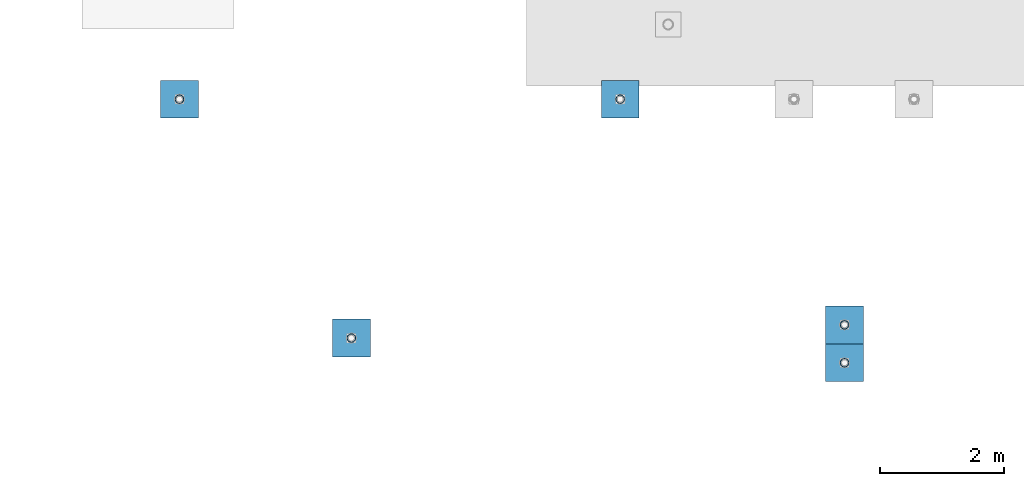
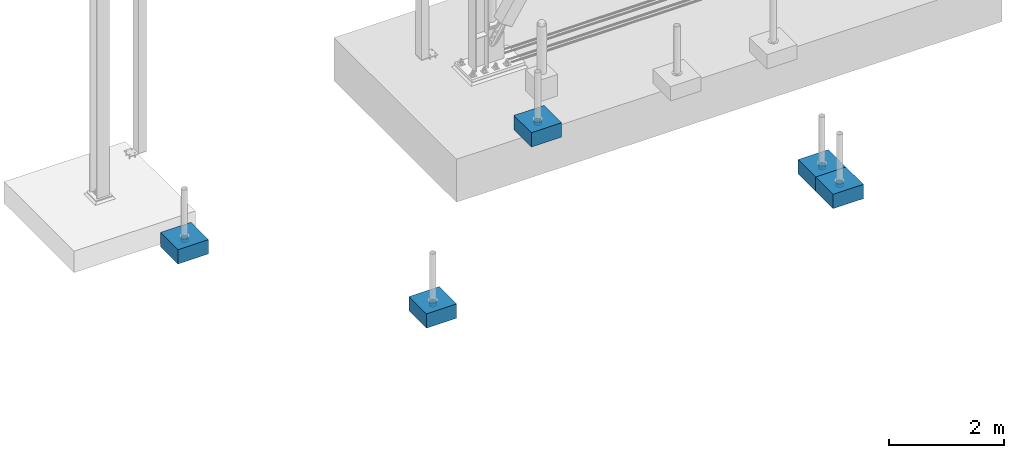
# One storey, part 1559 of 3843: 10 columns, 10 elements without a shape of their own.
"""IFC2X3 building model written with IfcOpenShell, lengths in millimetres."""

from ifc_helpers import new_model, si_unit, frame, origin_with_axes, place, context, subcontext, project, spatial, faceted_brep, material, type_object, element, aggregate, save


model = new_model("IFC2X3")

# Units and contexts
model_context = context("Model", 3, precision=1e-05, world=origin_with_axes())
body_context = subcontext(model_context, "Body", "Model", "MODEL_VIEW")
ifc_project = project(units=[si_unit("LENGTHUNIT", "METRE", prefix="MILLI"), si_unit("AREAUNIT", "SQUARE_METRE"), si_unit("VOLUMEUNIT", "CUBIC_METRE"), si_unit("MASSUNIT", "GRAM", prefix="KILO"), si_unit("TIMEUNIT", "SECOND"), si_unit("PLANEANGLEUNIT", "RADIAN"), si_unit("SOLIDANGLEUNIT", "STERADIAN"), si_unit("THERMODYNAMICTEMPERATUREUNIT", "DEGREE_CELSIUS"), si_unit("LUMINOUSINTENSITYUNIT", "LUMEN")], contexts=[model_context])

# Site, building, storey
site_placement = place(None, origin_with_axes())
site = spatial("IfcSite", under=ifc_project, at=site_placement, CompositionType="ELEMENT")
building_placement = place(site_placement, origin_with_axes())
building = spatial("IfcBuilding", under=site, at=building_placement, Name="Undefined", CompositionType="ELEMENT")
storey_placement = place(building_placement, origin_with_axes())
storey = spatial("IfcBuildingStorey", under=building, at=storey_placement, Name="Undefined", CompositionType="ELEMENT", Elevation=0.0)

# Assembly, column
assembly_1_placement = place(storey_placement, origin_with_axes())
assembly_1 = element("IfcElementAssembly", 1, at=assembly_1_placement, inside=storey, Name="PLATE", AssemblyPlace="NOTDEFINED", PredefinedType="RIGID_FRAME")
ifc_material_1 = material()
column_type_1 = type_object("IfcColumnType", Name="PIPE5SCH40", PredefinedType="NOTDEFINED")
column_1_placement = place(assembly_1_placement, frame((26313.3354032338, 82517.5288393497, 30378.4), z_axis=(-1.0, 0.0, 0.0), x_axis=(0.0, 0.0, 1.0)))
column_1 = element("IfcColumn", 2, at=column_1_placement, type_object=column_type_1, material=ifc_material_1, Name="PIPE_SLEEVE", ObjectType="PIPE5SCH40", context=body_context, shape_type="Brep", body=[
    faceted_brep([(0.0, -64.0587999999998, 0.0), (0.0, -60.9235391660477, 19.7952578392724), (76.2000000000007, -60.9235391660477, 19.7952578392724), (76.2000000000007, -64.0587999999998, 0.0), (0.0, -51.8246578392655, 37.6528179195593), (76.2000000000007, -51.8246578392655, 37.6528179195593), (0.0, -37.6528179195529, 51.8246578392718), (76.2000000000007, -37.6528179195529, 51.8246578392718), (0.0, -19.795257839266, 60.9235391660477), (76.2000000000007, -19.795257839266, 60.9235391660477), (0.0, 0.0, 64.0587999999989), (76.2000000000007, 0.0, 64.0587999999989), (0.0, 19.795257839266, 60.9235391660477), (76.2000000000007, 19.795257839266, 60.9235391660477), (0.0, 37.6528179195529, 51.8246578392718), (76.2000000000007, 37.6528179195529, 51.8246578392718), (0.0, 51.8246578392655, 37.6528179195593), (76.2000000000007, 51.8246578392655, 37.6528179195593), (0.0, 60.9235391660477, 19.7952578392724), (76.2000000000007, 60.9235391660477, 19.7952578392724), (0.0, 64.0587999999998, 0.0), (76.2000000000007, 64.0587999999998, 0.0), (0.0, 60.9235391660477, -19.7952578392724), (76.2000000000007, 60.9235391660477, -19.7952578392724), (0.0, 51.8246578392655, -37.6528179195593), (76.2000000000007, 51.8246578392655, -37.6528179195593), (0.0, 37.6528179195529, -51.8246578392718), (76.2000000000007, 37.6528179195529, -51.8246578392718), (0.0, 19.795257839266, -60.9235391660477), (76.2000000000007, 19.795257839266, -60.9235391660477), (0.0, 0.0, -64.0587999999989), (76.2000000000007, 0.0, -64.0587999999989), (0.0, -19.795257839266, -60.9235391660477), (76.2000000000007, -19.795257839266, -60.9235391660477), (0.0, -37.6528179195529, -51.8246578392718), (76.2000000000007, -37.6528179195529, -51.8246578392718), (0.0, -51.8246578392655, -37.6528179195593), (76.2000000000007, -51.8246578392655, -37.6528179195593), (0.0, -60.9235391660477, -19.7952578392724), (76.2000000000007, -60.9235391660477, -19.7952578392724), (0.0, -70.6120000000001, 0.0), (0.0, -67.1560027286332, -21.8203080068051), (76.2000000000007, -67.1560027286332, -21.8203080068051), (76.2000000000007, -70.6120000000001, 0.0), (0.0, -57.1263080068038, -41.5046922348702), (76.2000000000007, -57.1263080068038, -41.5046922348702), (0.0, -41.5046922348765, -57.126308006802), (76.2000000000007, -41.5046922348765, -57.126308006802), (0.0, -21.8203080068042, -67.1560027286323), (76.2000000000007, -21.8203080068042, -67.1560027286323), (0.0, 0.0, -70.6119999999937), (76.2000000000007, 0.0, -70.6119999999937), (0.0, 21.8203080068042, -67.1560027286323), (76.2000000000007, 21.8203080068042, -67.1560027286323), (0.0, 41.5046922348765, -57.126308006802), (76.2000000000007, 41.5046922348765, -57.126308006802), (0.0, 57.1263080068038, -41.5046922348702), (76.2000000000007, 57.1263080068038, -41.5046922348702), (0.0, 67.1560027286332, -21.8203080068051), (76.2000000000007, 67.1560027286332, -21.8203080068051), (0.0, 70.6120000000001, 0.0), (76.2000000000007, 70.6120000000001, 0.0), (0.0, 67.1560027286332, 21.8203080068051), (76.2000000000007, 67.1560027286332, 21.8203080068051), (0.0, 57.1263080068038, 41.5046922348702), (76.2000000000007, 57.1263080068038, 41.5046922348702), (0.0, 41.5046922348765, 57.126308006802), (76.2000000000007, 41.5046922348765, 57.126308006802), (0.0, 21.8203080068042, 67.1560027286323), (76.2000000000007, 21.8203080068042, 67.1560027286323), (0.0, 0.0, 70.6119999999937), (76.2000000000007, 0.0, 70.6119999999937), (0.0, -21.8203080068042, 67.1560027286323), (76.2000000000007, -21.8203080068042, 67.1560027286323), (0.0, -41.5046922348765, 57.126308006802), (76.2000000000007, -41.5046922348765, 57.126308006802), (0.0, -57.1263080068038, 41.5046922348702), (76.2000000000007, -57.1263080068038, 41.5046922348702), (0.0, -67.1560027286332, 21.8203080068051), (76.2000000000007, -67.1560027286332, 21.8203080068051)], [[[0, 1, 2, 3]], [[1, 4, 5, 2]], [[4, 6, 7, 5]], [[6, 8, 9, 7]], [[8, 10, 11, 9]], [[10, 12, 13, 11]], [[12, 14, 15, 13]], [[14, 16, 17, 15]], [[16, 18, 19, 17]], [[18, 20, 21, 19]], [[20, 22, 23, 21]], [[22, 24, 25, 23]], [[24, 26, 27, 25]], [[26, 28, 29, 27]], [[28, 30, 31, 29]], [[30, 32, 33, 31]], [[32, 34, 35, 33]], [[34, 36, 37, 35]], [[36, 38, 39, 37]], [[38, 0, 3, 39]], [[40, 41, 42, 43]], [[41, 44, 45, 42]], [[44, 46, 47, 45]], [[46, 48, 49, 47]], [[48, 50, 51, 49]], [[50, 52, 53, 51]], [[52, 54, 55, 53]], [[54, 56, 57, 55]], [[56, 58, 59, 57]], [[58, 60, 61, 59]], [[60, 62, 63, 61]], [[62, 64, 65, 63]], [[64, 66, 67, 65]], [[66, 68, 69, 67]], [[68, 70, 71, 69]], [[70, 72, 73, 71]], [[72, 74, 75, 73]], [[74, 76, 77, 75]], [[76, 78, 79, 77]], [[78, 40, 43, 79]], [[45, 47, 49, 51, 53, 55, 57, 59, 61, 63, 65, 67, 69, 71, 73, 75, 77, 79, 43, 42], [5, 7, 9, 11, 13, 15, 17, 19, 21, 23, 25, 27, 29, 31, 33, 35, 37, 39, 3, 2]], [[78, 76, 74, 72, 70, 68, 66, 64, 62, 60, 58, 56, 54, 52, 50, 48, 46, 44, 41, 40], [38, 36, 34, 32, 30, 28, 26, 24, 22, 20, 18, 16, 14, 12, 10, 8, 6, 4, 1, 0]]]),
])
aggregate(assembly_1, [column_1])

assembly_2_placement = place(storey_placement, origin_with_axes())
assembly_2 = element("IfcElementAssembly", 3, at=assembly_2_placement, inside=storey, Name="PLATE", AssemblyPlace="NOTDEFINED", PredefinedType="RIGID_FRAME")
column_2_placement = place(assembly_2_placement, frame((26313.3354032338, 83128.8302614689, 30378.4), z_axis=(-1.0, 0.0, 0.0), x_axis=(0.0, 0.0, 1.0)))
column_2 = element("IfcColumn", 4, at=column_2_placement, type_object=column_type_1, material=ifc_material_1, Name="PIPE_SLEEVE", ObjectType="PIPE5SCH40", context=body_context, shape_type="Brep", body=[
    faceted_brep([(0.0, -64.0587999999998, 0.0), (0.0, -60.9235391660477, 19.7952578392724), (76.2000000000007, -60.9235391660477, 19.7952578392724), (76.2000000000007, -64.0587999999998, 0.0), (0.0, -51.8246578392655, 37.6528179195593), (76.2000000000007, -51.8246578392655, 37.6528179195593), (0.0, -37.6528179195529, 51.8246578392718), (76.2000000000007, -37.6528179195529, 51.8246578392718), (0.0, -19.795257839266, 60.9235391660477), (76.2000000000007, -19.795257839266, 60.9235391660477), (0.0, 0.0, 64.0587999999989), (76.2000000000007, 0.0, 64.0587999999989), (0.0, 19.795257839266, 60.9235391660477), (76.2000000000007, 19.795257839266, 60.9235391660477), (0.0, 37.6528179195529, 51.8246578392718), (76.2000000000007, 37.6528179195529, 51.8246578392718), (0.0, 51.8246578392655, 37.6528179195593), (76.2000000000007, 51.8246578392655, 37.6528179195593), (0.0, 60.9235391660477, 19.7952578392724), (76.2000000000007, 60.9235391660477, 19.7952578392724), (0.0, 64.0587999999998, 0.0), (76.2000000000007, 64.0587999999998, 0.0), (0.0, 60.9235391660477, -19.7952578392724), (76.2000000000007, 60.9235391660477, -19.7952578392724), (0.0, 51.8246578392655, -37.6528179195593), (76.2000000000007, 51.8246578392655, -37.6528179195593), (0.0, 37.6528179195529, -51.8246578392718), (76.2000000000007, 37.6528179195529, -51.8246578392718), (0.0, 19.795257839266, -60.9235391660477), (76.2000000000007, 19.795257839266, -60.9235391660477), (0.0, 0.0, -64.0587999999989), (76.2000000000007, 0.0, -64.0587999999989), (0.0, -19.795257839266, -60.9235391660477), (76.2000000000007, -19.795257839266, -60.9235391660477), (0.0, -37.6528179195529, -51.8246578392718), (76.2000000000007, -37.6528179195529, -51.8246578392718), (0.0, -51.8246578392655, -37.6528179195593), (76.2000000000007, -51.8246578392655, -37.6528179195593), (0.0, -60.9235391660477, -19.7952578392724), (76.2000000000007, -60.9235391660477, -19.7952578392724), (0.0, -70.6120000000001, 0.0), (0.0, -67.1560027286332, -21.8203080068051), (76.2000000000007, -67.1560027286332, -21.8203080068051), (76.2000000000007, -70.6120000000001, 0.0), (0.0, -57.1263080068038, -41.5046922348702), (76.2000000000007, -57.1263080068038, -41.5046922348702), (0.0, -41.5046922348765, -57.126308006802), (76.2000000000007, -41.5046922348765, -57.126308006802), (0.0, -21.8203080068042, -67.1560027286323), (76.2000000000007, -21.8203080068042, -67.1560027286323), (0.0, 0.0, -70.6119999999937), (76.2000000000007, 0.0, -70.6119999999937), (0.0, 21.8203080068042, -67.1560027286323), (76.2000000000007, 21.8203080068042, -67.1560027286323), (0.0, 41.5046922348765, -57.126308006802), (76.2000000000007, 41.5046922348765, -57.126308006802), (0.0, 57.1263080068038, -41.5046922348702), (76.2000000000007, 57.1263080068038, -41.5046922348702), (0.0, 67.1560027286332, -21.8203080068051), (76.2000000000007, 67.1560027286332, -21.8203080068051), (0.0, 70.6120000000001, 0.0), (76.2000000000007, 70.6120000000001, 0.0), (0.0, 67.1560027286332, 21.8203080068051), (76.2000000000007, 67.1560027286332, 21.8203080068051), (0.0, 57.1263080068038, 41.5046922348702), (76.2000000000007, 57.1263080068038, 41.5046922348702), (0.0, 41.5046922348765, 57.126308006802), (76.2000000000007, 41.5046922348765, 57.126308006802), (0.0, 21.8203080068042, 67.1560027286323), (76.2000000000007, 21.8203080068042, 67.1560027286323), (0.0, 0.0, 70.6119999999937), (76.2000000000007, 0.0, 70.6119999999937), (0.0, -21.8203080068042, 67.1560027286323), (76.2000000000007, -21.8203080068042, 67.1560027286323), (0.0, -41.5046922348765, 57.126308006802), (76.2000000000007, -41.5046922348765, 57.126308006802), (0.0, -57.1263080068038, 41.5046922348702), (76.2000000000007, -57.1263080068038, 41.5046922348702), (0.0, -67.1560027286332, 21.8203080068051), (76.2000000000007, -67.1560027286332, 21.8203080068051)], [[[0, 1, 2, 3]], [[1, 4, 5, 2]], [[4, 6, 7, 5]], [[6, 8, 9, 7]], [[8, 10, 11, 9]], [[10, 12, 13, 11]], [[12, 14, 15, 13]], [[14, 16, 17, 15]], [[16, 18, 19, 17]], [[18, 20, 21, 19]], [[20, 22, 23, 21]], [[22, 24, 25, 23]], [[24, 26, 27, 25]], [[26, 28, 29, 27]], [[28, 30, 31, 29]], [[30, 32, 33, 31]], [[32, 34, 35, 33]], [[34, 36, 37, 35]], [[36, 38, 39, 37]], [[38, 0, 3, 39]], [[40, 41, 42, 43]], [[41, 44, 45, 42]], [[44, 46, 47, 45]], [[46, 48, 49, 47]], [[48, 50, 51, 49]], [[50, 52, 53, 51]], [[52, 54, 55, 53]], [[54, 56, 57, 55]], [[56, 58, 59, 57]], [[58, 60, 61, 59]], [[60, 62, 63, 61]], [[62, 64, 65, 63]], [[64, 66, 67, 65]], [[66, 68, 69, 67]], [[68, 70, 71, 69]], [[70, 72, 73, 71]], [[72, 74, 75, 73]], [[74, 76, 77, 75]], [[76, 78, 79, 77]], [[78, 40, 43, 79]], [[45, 47, 49, 51, 53, 55, 57, 59, 61, 63, 65, 67, 69, 71, 73, 75, 77, 79, 43, 42], [5, 7, 9, 11, 13, 15, 17, 19, 21, 23, 25, 27, 29, 31, 33, 35, 37, 39, 3, 2]], [[78, 76, 74, 72, 70, 68, 66, 64, 62, 60, 58, 56, 54, 52, 50, 48, 46, 44, 41, 40], [38, 36, 34, 32, 30, 28, 26, 24, 22, 20, 18, 16, 14, 12, 10, 8, 6, 4, 1, 0]]]),
])
aggregate(assembly_2, [column_2])

assembly_3_placement = place(storey_placement, origin_with_axes())
assembly_3 = element("IfcElementAssembly", 5, at=assembly_3_placement, inside=storey, Name="PLATE", AssemblyPlace="NOTDEFINED", PredefinedType="RIGID_FRAME")
column_3_placement = place(assembly_3_placement, frame((22696.0234487355, 86768.0056765079, 30378.4), z_axis=(-1.0, 0.0, 0.0), x_axis=(0.0, 0.0, 1.0)))
column_3 = element("IfcColumn", 6, at=column_3_placement, type_object=column_type_1, material=ifc_material_1, Name="PIPE_SLEEVE", ObjectType="PIPE5SCH40", context=body_context, shape_type="Brep", body=[
    faceted_brep([(0.0, -64.0587999999998, 0.0), (0.0, -60.9235391660477, 19.7952578392724), (76.2000000000007, -60.9235391660477, 19.7952578392724), (76.2000000000007, -64.0587999999998, 0.0), (0.0, -51.8246578392655, 37.6528179195593), (76.2000000000007, -51.8246578392655, 37.6528179195593), (0.0, -37.6528179195529, 51.8246578392718), (76.2000000000007, -37.6528179195529, 51.8246578392718), (0.0, -19.795257839266, 60.9235391660477), (76.2000000000007, -19.795257839266, 60.9235391660477), (0.0, 0.0, 64.0587999999989), (76.2000000000007, 0.0, 64.0587999999989), (0.0, 19.795257839266, 60.9235391660477), (76.2000000000007, 19.795257839266, 60.9235391660477), (0.0, 37.6528179195529, 51.8246578392718), (76.2000000000007, 37.6528179195529, 51.8246578392718), (0.0, 51.8246578392655, 37.6528179195593), (76.2000000000007, 51.8246578392655, 37.6528179195593), (0.0, 60.9235391660477, 19.7952578392724), (76.2000000000007, 60.9235391660477, 19.7952578392724), (0.0, 64.0587999999998, 0.0), (76.2000000000007, 64.0587999999998, 0.0), (0.0, 60.9235391660477, -19.7952578392724), (76.2000000000007, 60.9235391660477, -19.7952578392724), (0.0, 51.8246578392655, -37.6528179195593), (76.2000000000007, 51.8246578392655, -37.6528179195593), (0.0, 37.6528179195529, -51.8246578392718), (76.2000000000007, 37.6528179195529, -51.8246578392718), (0.0, 19.795257839266, -60.9235391660477), (76.2000000000007, 19.795257839266, -60.9235391660477), (0.0, 0.0, -64.0587999999989), (76.2000000000007, 0.0, -64.0587999999989), (0.0, -19.795257839266, -60.9235391660477), (76.2000000000007, -19.795257839266, -60.9235391660477), (0.0, -37.6528179195529, -51.8246578392718), (76.2000000000007, -37.6528179195529, -51.8246578392718), (0.0, -51.8246578392655, -37.6528179195593), (76.2000000000007, -51.8246578392655, -37.6528179195593), (0.0, -60.9235391660477, -19.7952578392724), (76.2000000000007, -60.9235391660477, -19.7952578392724), (0.0, -70.6120000000001, 0.0), (0.0, -67.1560027286332, -21.8203080068051), (76.2000000000007, -67.1560027286332, -21.8203080068051), (76.2000000000007, -70.6120000000001, 0.0), (0.0, -57.1263080068038, -41.5046922348702), (76.2000000000007, -57.1263080068038, -41.5046922348702), (0.0, -41.5046922348765, -57.126308006802), (76.2000000000007, -41.5046922348765, -57.126308006802), (0.0, -21.8203080068042, -67.1560027286323), (76.2000000000007, -21.8203080068042, -67.1560027286323), (0.0, 0.0, -70.6119999999937), (76.2000000000007, 0.0, -70.6119999999937), (0.0, 21.8203080068042, -67.1560027286323), (76.2000000000007, 21.8203080068042, -67.1560027286323), (0.0, 41.5046922348765, -57.126308006802), (76.2000000000007, 41.5046922348765, -57.126308006802), (0.0, 57.1263080068038, -41.5046922348702), (76.2000000000007, 57.1263080068038, -41.5046922348702), (0.0, 67.1560027286332, -21.8203080068051), (76.2000000000007, 67.1560027286332, -21.8203080068051), (0.0, 70.6120000000001, 0.0), (76.2000000000007, 70.6120000000001, 0.0), (0.0, 67.1560027286332, 21.8203080068051), (76.2000000000007, 67.1560027286332, 21.8203080068051), (0.0, 57.1263080068038, 41.5046922348702), (76.2000000000007, 57.1263080068038, 41.5046922348702), (0.0, 41.5046922348765, 57.126308006802), (76.2000000000007, 41.5046922348765, 57.126308006802), (0.0, 21.8203080068042, 67.1560027286323), (76.2000000000007, 21.8203080068042, 67.1560027286323), (0.0, 0.0, 70.6119999999937), (76.2000000000007, 0.0, 70.6119999999937), (0.0, -21.8203080068042, 67.1560027286323), (76.2000000000007, -21.8203080068042, 67.1560027286323), (0.0, -41.5046922348765, 57.126308006802), (76.2000000000007, -41.5046922348765, 57.126308006802), (0.0, -57.1263080068038, 41.5046922348702), (76.2000000000007, -57.1263080068038, 41.5046922348702), (0.0, -67.1560027286332, 21.8203080068051), (76.2000000000007, -67.1560027286332, 21.8203080068051)], [[[0, 1, 2, 3]], [[1, 4, 5, 2]], [[4, 6, 7, 5]], [[6, 8, 9, 7]], [[8, 10, 11, 9]], [[10, 12, 13, 11]], [[12, 14, 15, 13]], [[14, 16, 17, 15]], [[16, 18, 19, 17]], [[18, 20, 21, 19]], [[20, 22, 23, 21]], [[22, 24, 25, 23]], [[24, 26, 27, 25]], [[26, 28, 29, 27]], [[28, 30, 31, 29]], [[30, 32, 33, 31]], [[32, 34, 35, 33]], [[34, 36, 37, 35]], [[36, 38, 39, 37]], [[38, 0, 3, 39]], [[40, 41, 42, 43]], [[41, 44, 45, 42]], [[44, 46, 47, 45]], [[46, 48, 49, 47]], [[48, 50, 51, 49]], [[50, 52, 53, 51]], [[52, 54, 55, 53]], [[54, 56, 57, 55]], [[56, 58, 59, 57]], [[58, 60, 61, 59]], [[60, 62, 63, 61]], [[62, 64, 65, 63]], [[64, 66, 67, 65]], [[66, 68, 69, 67]], [[68, 70, 71, 69]], [[70, 72, 73, 71]], [[72, 74, 75, 73]], [[74, 76, 77, 75]], [[76, 78, 79, 77]], [[78, 40, 43, 79]], [[45, 47, 49, 51, 53, 55, 57, 59, 61, 63, 65, 67, 69, 71, 73, 75, 77, 79, 43, 42], [5, 7, 9, 11, 13, 15, 17, 19, 21, 23, 25, 27, 29, 31, 33, 35, 37, 39, 3, 2]], [[78, 76, 74, 72, 70, 68, 66, 64, 62, 60, 58, 56, 54, 52, 50, 48, 46, 44, 41, 40], [38, 36, 34, 32, 30, 28, 26, 24, 22, 20, 18, 16, 14, 12, 10, 8, 6, 4, 1, 0]]]),
])
aggregate(assembly_3, [column_3])

assembly_4_placement = place(storey_placement, origin_with_axes())
assembly_4 = element("IfcElementAssembly", 7, at=assembly_4_placement, inside=storey, Name="PLATE", AssemblyPlace="NOTDEFINED", PredefinedType="RIGID_FRAME")
column_4_placement = place(assembly_4_placement, frame((18362.1048772633, 82916.2028505802, 30378.4), z_axis=(-1.0, 0.0, 0.0), x_axis=(0.0, 0.0, 1.0)))
column_4 = element("IfcColumn", 8, at=column_4_placement, type_object=column_type_1, material=ifc_material_1, Name="PIPE_SLEEVE", ObjectType="PIPE5SCH40", context=body_context, shape_type="Brep", body=[
    faceted_brep([(0.0, -64.0587999999998, 0.0), (0.0, -60.9235391660477, 19.7952578392724), (76.2000000000007, -60.9235391660477, 19.7952578392724), (76.2000000000007, -64.0587999999998, 0.0), (0.0, -51.8246578392655, 37.6528179195593), (76.2000000000007, -51.8246578392655, 37.6528179195593), (0.0, -37.6528179195529, 51.8246578392718), (76.2000000000007, -37.6528179195529, 51.8246578392718), (0.0, -19.795257839266, 60.9235391660477), (76.2000000000007, -19.795257839266, 60.9235391660477), (0.0, 0.0, 64.0587999999989), (76.2000000000007, 0.0, 64.0587999999989), (0.0, 19.795257839266, 60.9235391660477), (76.2000000000007, 19.795257839266, 60.9235391660477), (0.0, 37.6528179195529, 51.8246578392718), (76.2000000000007, 37.6528179195529, 51.8246578392718), (0.0, 51.8246578392655, 37.6528179195593), (76.2000000000007, 51.8246578392655, 37.6528179195593), (0.0, 60.9235391660477, 19.7952578392724), (76.2000000000007, 60.9235391660477, 19.7952578392724), (0.0, 64.0587999999998, 0.0), (76.2000000000007, 64.0587999999998, 0.0), (0.0, 60.9235391660477, -19.7952578392724), (76.2000000000007, 60.9235391660477, -19.7952578392724), (0.0, 51.8246578392655, -37.6528179195593), (76.2000000000007, 51.8246578392655, -37.6528179195593), (0.0, 37.6528179195529, -51.8246578392718), (76.2000000000007, 37.6528179195529, -51.8246578392718), (0.0, 19.795257839266, -60.9235391660477), (76.2000000000007, 19.795257839266, -60.9235391660477), (0.0, 0.0, -64.0587999999989), (76.2000000000007, 0.0, -64.0587999999989), (0.0, -19.795257839266, -60.9235391660477), (76.2000000000007, -19.795257839266, -60.9235391660477), (0.0, -37.6528179195529, -51.8246578392718), (76.2000000000007, -37.6528179195529, -51.8246578392718), (0.0, -51.8246578392655, -37.6528179195593), (76.2000000000007, -51.8246578392655, -37.6528179195593), (0.0, -60.9235391660477, -19.7952578392724), (76.2000000000007, -60.9235391660477, -19.7952578392724), (0.0, -70.6120000000001, 0.0), (0.0, -67.1560027286332, -21.8203080068051), (76.2000000000007, -67.1560027286332, -21.8203080068051), (76.2000000000007, -70.6120000000001, 0.0), (0.0, -57.1263080068038, -41.5046922348702), (76.2000000000007, -57.1263080068038, -41.5046922348702), (0.0, -41.5046922348765, -57.126308006802), (76.2000000000007, -41.5046922348765, -57.126308006802), (0.0, -21.8203080068042, -67.1560027286323), (76.2000000000007, -21.8203080068042, -67.1560027286323), (0.0, 0.0, -70.6119999999937), (76.2000000000007, 0.0, -70.6119999999937), (0.0, 21.8203080068042, -67.1560027286323), (76.2000000000007, 21.8203080068042, -67.1560027286323), (0.0, 41.5046922348765, -57.126308006802), (76.2000000000007, 41.5046922348765, -57.126308006802), (0.0, 57.1263080068038, -41.5046922348702), (76.2000000000007, 57.1263080068038, -41.5046922348702), (0.0, 67.1560027286332, -21.8203080068051), (76.2000000000007, 67.1560027286332, -21.8203080068051), (0.0, 70.6120000000001, 0.0), (76.2000000000007, 70.6120000000001, 0.0), (0.0, 67.1560027286332, 21.8203080068051), (76.2000000000007, 67.1560027286332, 21.8203080068051), (0.0, 57.1263080068038, 41.5046922348702), (76.2000000000007, 57.1263080068038, 41.5046922348702), (0.0, 41.5046922348765, 57.126308006802), (76.2000000000007, 41.5046922348765, 57.126308006802), (0.0, 21.8203080068042, 67.1560027286323), (76.2000000000007, 21.8203080068042, 67.1560027286323), (0.0, 0.0, 70.6119999999937), (76.2000000000007, 0.0, 70.6119999999937), (0.0, -21.8203080068042, 67.1560027286323), (76.2000000000007, -21.8203080068042, 67.1560027286323), (0.0, -41.5046922348765, 57.126308006802), (76.2000000000007, -41.5046922348765, 57.126308006802), (0.0, -57.1263080068038, 41.5046922348702), (76.2000000000007, -57.1263080068038, 41.5046922348702), (0.0, -67.1560027286332, 21.8203080068051), (76.2000000000007, -67.1560027286332, 21.8203080068051)], [[[0, 1, 2, 3]], [[1, 4, 5, 2]], [[4, 6, 7, 5]], [[6, 8, 9, 7]], [[8, 10, 11, 9]], [[10, 12, 13, 11]], [[12, 14, 15, 13]], [[14, 16, 17, 15]], [[16, 18, 19, 17]], [[18, 20, 21, 19]], [[20, 22, 23, 21]], [[22, 24, 25, 23]], [[24, 26, 27, 25]], [[26, 28, 29, 27]], [[28, 30, 31, 29]], [[30, 32, 33, 31]], [[32, 34, 35, 33]], [[34, 36, 37, 35]], [[36, 38, 39, 37]], [[38, 0, 3, 39]], [[40, 41, 42, 43]], [[41, 44, 45, 42]], [[44, 46, 47, 45]], [[46, 48, 49, 47]], [[48, 50, 51, 49]], [[50, 52, 53, 51]], [[52, 54, 55, 53]], [[54, 56, 57, 55]], [[56, 58, 59, 57]], [[58, 60, 61, 59]], [[60, 62, 63, 61]], [[62, 64, 65, 63]], [[64, 66, 67, 65]], [[66, 68, 69, 67]], [[68, 70, 71, 69]], [[70, 72, 73, 71]], [[72, 74, 75, 73]], [[74, 76, 77, 75]], [[76, 78, 79, 77]], [[78, 40, 43, 79]], [[45, 47, 49, 51, 53, 55, 57, 59, 61, 63, 65, 67, 69, 71, 73, 75, 77, 79, 43, 42], [5, 7, 9, 11, 13, 15, 17, 19, 21, 23, 25, 27, 29, 31, 33, 35, 37, 39, 3, 2]], [[78, 76, 74, 72, 70, 68, 66, 64, 62, 60, 58, 56, 54, 52, 50, 48, 46, 44, 41, 40], [38, 36, 34, 32, 30, 28, 26, 24, 22, 20, 18, 16, 14, 12, 10, 8, 6, 4, 1, 0]]]),
])
aggregate(assembly_4, [column_4])

assembly_5_placement = place(storey_placement, origin_with_axes())
assembly_5 = element("IfcElementAssembly", 9, at=assembly_5_placement, inside=storey, Name="PLATE", AssemblyPlace="NOTDEFINED", PredefinedType="RIGID_FRAME")
column_5_placement = place(assembly_5_placement, frame((15589.6291578114, 86768.0056765079, 30378.4), z_axis=(-1.0, 0.0, 0.0), x_axis=(0.0, 0.0, 1.0)))
column_5 = element("IfcColumn", 10, at=column_5_placement, type_object=column_type_1, material=ifc_material_1, Name="PIPE_SLEEVE", ObjectType="PIPE5SCH40", context=body_context, shape_type="Brep", body=[
    faceted_brep([(0.0, -64.0587999999998, 0.0), (0.0, -60.9235391660477, 19.7952578392724), (76.2000000000007, -60.9235391660477, 19.7952578392724), (76.2000000000007, -64.0587999999998, 0.0), (0.0, -51.8246578392655, 37.6528179195593), (76.2000000000007, -51.8246578392655, 37.6528179195593), (0.0, -37.6528179195529, 51.8246578392718), (76.2000000000007, -37.6528179195529, 51.8246578392718), (0.0, -19.795257839266, 60.9235391660477), (76.2000000000007, -19.795257839266, 60.9235391660477), (0.0, 0.0, 64.0587999999989), (76.2000000000007, 0.0, 64.0587999999989), (0.0, 19.795257839266, 60.9235391660477), (76.2000000000007, 19.795257839266, 60.9235391660477), (0.0, 37.6528179195529, 51.8246578392718), (76.2000000000007, 37.6528179195529, 51.8246578392718), (0.0, 51.8246578392655, 37.6528179195593), (76.2000000000007, 51.8246578392655, 37.6528179195593), (0.0, 60.9235391660477, 19.7952578392724), (76.2000000000007, 60.9235391660477, 19.7952578392724), (0.0, 64.0587999999998, 0.0), (76.2000000000007, 64.0587999999998, 0.0), (0.0, 60.9235391660477, -19.7952578392724), (76.2000000000007, 60.9235391660477, -19.7952578392724), (0.0, 51.8246578392655, -37.6528179195593), (76.2000000000007, 51.8246578392655, -37.6528179195593), (0.0, 37.6528179195529, -51.8246578392718), (76.2000000000007, 37.6528179195529, -51.8246578392718), (0.0, 19.795257839266, -60.9235391660477), (76.2000000000007, 19.795257839266, -60.9235391660477), (0.0, 0.0, -64.0587999999989), (76.2000000000007, 0.0, -64.0587999999989), (0.0, -19.795257839266, -60.9235391660477), (76.2000000000007, -19.795257839266, -60.9235391660477), (0.0, -37.6528179195529, -51.8246578392718), (76.2000000000007, -37.6528179195529, -51.8246578392718), (0.0, -51.8246578392655, -37.6528179195593), (76.2000000000007, -51.8246578392655, -37.6528179195593), (0.0, -60.9235391660477, -19.7952578392724), (76.2000000000007, -60.9235391660477, -19.7952578392724), (0.0, -70.6120000000001, 0.0), (0.0, -67.1560027286332, -21.8203080068051), (76.2000000000007, -67.1560027286332, -21.8203080068051), (76.2000000000007, -70.6120000000001, 0.0), (0.0, -57.1263080068038, -41.5046922348702), (76.2000000000007, -57.1263080068038, -41.5046922348702), (0.0, -41.5046922348765, -57.126308006802), (76.2000000000007, -41.5046922348765, -57.126308006802), (0.0, -21.8203080068042, -67.1560027286323), (76.2000000000007, -21.8203080068042, -67.1560027286323), (0.0, 0.0, -70.6119999999937), (76.2000000000007, 0.0, -70.6119999999937), (0.0, 21.8203080068042, -67.1560027286323), (76.2000000000007, 21.8203080068042, -67.1560027286323), (0.0, 41.5046922348765, -57.126308006802), (76.2000000000007, 41.5046922348765, -57.126308006802), (0.0, 57.1263080068038, -41.5046922348702), (76.2000000000007, 57.1263080068038, -41.5046922348702), (0.0, 67.1560027286332, -21.8203080068051), (76.2000000000007, 67.1560027286332, -21.8203080068051), (0.0, 70.6120000000001, 0.0), (76.2000000000007, 70.6120000000001, 0.0), (0.0, 67.1560027286332, 21.8203080068051), (76.2000000000007, 67.1560027286332, 21.8203080068051), (0.0, 57.1263080068038, 41.5046922348702), (76.2000000000007, 57.1263080068038, 41.5046922348702), (0.0, 41.5046922348765, 57.126308006802), (76.2000000000007, 41.5046922348765, 57.126308006802), (0.0, 21.8203080068042, 67.1560027286323), (76.2000000000007, 21.8203080068042, 67.1560027286323), (0.0, 0.0, 70.6119999999937), (76.2000000000007, 0.0, 70.6119999999937), (0.0, -21.8203080068042, 67.1560027286323), (76.2000000000007, -21.8203080068042, 67.1560027286323), (0.0, -41.5046922348765, 57.126308006802), (76.2000000000007, -41.5046922348765, 57.126308006802), (0.0, -57.1263080068038, 41.5046922348702), (76.2000000000007, -57.1263080068038, 41.5046922348702), (0.0, -67.1560027286332, 21.8203080068051), (76.2000000000007, -67.1560027286332, 21.8203080068051)], [[[0, 1, 2, 3]], [[1, 4, 5, 2]], [[4, 6, 7, 5]], [[6, 8, 9, 7]], [[8, 10, 11, 9]], [[10, 12, 13, 11]], [[12, 14, 15, 13]], [[14, 16, 17, 15]], [[16, 18, 19, 17]], [[18, 20, 21, 19]], [[20, 22, 23, 21]], [[22, 24, 25, 23]], [[24, 26, 27, 25]], [[26, 28, 29, 27]], [[28, 30, 31, 29]], [[30, 32, 33, 31]], [[32, 34, 35, 33]], [[34, 36, 37, 35]], [[36, 38, 39, 37]], [[38, 0, 3, 39]], [[40, 41, 42, 43]], [[41, 44, 45, 42]], [[44, 46, 47, 45]], [[46, 48, 49, 47]], [[48, 50, 51, 49]], [[50, 52, 53, 51]], [[52, 54, 55, 53]], [[54, 56, 57, 55]], [[56, 58, 59, 57]], [[58, 60, 61, 59]], [[60, 62, 63, 61]], [[62, 64, 65, 63]], [[64, 66, 67, 65]], [[66, 68, 69, 67]], [[68, 70, 71, 69]], [[70, 72, 73, 71]], [[72, 74, 75, 73]], [[74, 76, 77, 75]], [[76, 78, 79, 77]], [[78, 40, 43, 79]], [[45, 47, 49, 51, 53, 55, 57, 59, 61, 63, 65, 67, 69, 71, 73, 75, 77, 79, 43, 42], [5, 7, 9, 11, 13, 15, 17, 19, 21, 23, 25, 27, 29, 31, 33, 35, 37, 39, 3, 2]], [[78, 76, 74, 72, 70, 68, 66, 64, 62, 60, 58, 56, 54, 52, 50, 48, 46, 44, 41, 40], [38, 36, 34, 32, 30, 28, 26, 24, 22, 20, 18, 16, 14, 12, 10, 8, 6, 4, 1, 0]]]),
])
aggregate(assembly_5, [column_5])

assembly_6_placement = place(storey_placement, origin_with_axes())
assembly_6 = element("IfcElementAssembly", 11, at=assembly_6_placement, inside=storey, Name="CONC_COL.", AssemblyPlace="NOTDEFINED", PredefinedType="REINFORCEMENT_UNIT")
ifc_material_2 = material(Name="CONCRETE/3000")
column_type_2 = type_object("IfcColumnType", PredefinedType="NOTDEFINED")
column_6_placement = place(assembly_6_placement, frame((26313.3354032338, 82517.5288393497, 30175.2), z_axis=(-1.0, 0.0, 0.0), x_axis=(0.0, 0.0, 1.0)))
column_6 = element("IfcColumn", 12, at=column_6_placement, type_object=column_type_2, material=ifc_material_2, Name="CONC_COL.", context=body_context, shape_type="Brep", body=[
    faceted_brep([(0.0, 304.8, -304.800000000003), (0.0, 304.8, 304.800000000003), (304.799999999999, 304.8, 304.800000000003), (304.799999999999, 304.8, -304.800000000003), (0.0, -304.8, 304.800000000003), (304.799999999999, -304.8, 304.800000000003), (0.0, -304.8, -304.800000000003), (304.799999999999, -304.8, -304.800000000003)], [[[0, 1, 2, 3]], [[1, 4, 5, 2]], [[4, 6, 7, 5]], [[6, 0, 3, 7]], [[5, 7, 3, 2]], [[6, 4, 1, 0]]]),
])
aggregate(assembly_6, [column_6])

assembly_7_placement = place(storey_placement, origin_with_axes())
assembly_7 = element("IfcElementAssembly", 13, at=assembly_7_placement, inside=storey, Name="CONC_COL.", AssemblyPlace="NOTDEFINED", PredefinedType="REINFORCEMENT_UNIT")
column_7_placement = place(assembly_7_placement, frame((26313.3354032338, 83128.8302614689, 30175.2), z_axis=(-1.0, 0.0, 0.0), x_axis=(0.0, 0.0, 1.0)))
column_7 = element("IfcColumn", 14, at=column_7_placement, type_object=column_type_2, material=ifc_material_2, Name="CONC_COL.", context=body_context, shape_type="Brep", body=[
    faceted_brep([(0.0, 304.8, -304.800000000003), (0.0, 304.8, 304.800000000003), (304.799999999999, 304.8, 304.800000000003), (304.799999999999, 304.8, -304.800000000003), (0.0, -304.8, 304.800000000003), (304.799999999999, -304.8, 304.800000000003), (0.0, -304.8, -304.800000000003), (304.799999999999, -304.8, -304.800000000003)], [[[0, 1, 2, 3]], [[1, 4, 5, 2]], [[4, 6, 7, 5]], [[6, 0, 3, 7]], [[5, 7, 3, 2]], [[6, 4, 1, 0]]]),
])
aggregate(assembly_7, [column_7])

assembly_8_placement = place(storey_placement, origin_with_axes())
assembly_8 = element("IfcElementAssembly", 15, at=assembly_8_placement, inside=storey, Name="CONC_COL.", AssemblyPlace="NOTDEFINED", PredefinedType="REINFORCEMENT_UNIT")
column_8_placement = place(assembly_8_placement, frame((22696.0234487355, 86768.0056765079, 30175.2), z_axis=(-1.0, 0.0, 0.0), x_axis=(0.0, 0.0, 1.0)))
column_8 = element("IfcColumn", 16, at=column_8_placement, type_object=column_type_2, material=ifc_material_2, Name="CONC_COL.", context=body_context, shape_type="Brep", body=[
    faceted_brep([(0.0, 304.8, -304.800000000003), (0.0, 304.8, 304.800000000003), (304.799999999999, 304.8, 304.800000000003), (304.799999999999, 304.8, -304.800000000003), (0.0, -304.8, 304.800000000003), (304.799999999999, -304.8, 304.800000000003), (0.0, -304.8, -304.800000000003), (304.799999999999, -304.8, -304.800000000003)], [[[0, 1, 2, 3]], [[1, 4, 5, 2]], [[4, 6, 7, 5]], [[6, 0, 3, 7]], [[5, 7, 3, 2]], [[6, 4, 1, 0]]]),
])
aggregate(assembly_8, [column_8])

assembly_9_placement = place(storey_placement, origin_with_axes())
assembly_9 = element("IfcElementAssembly", 17, at=assembly_9_placement, inside=storey, Name="CONC_COL.", AssemblyPlace="NOTDEFINED", PredefinedType="REINFORCEMENT_UNIT")
column_9_placement = place(assembly_9_placement, frame((18362.1048772633, 82916.2028505802, 30175.2), z_axis=(-1.0, 0.0, 0.0), x_axis=(0.0, 0.0, 1.0)))
column_9 = element("IfcColumn", 18, at=column_9_placement, type_object=column_type_2, material=ifc_material_2, Name="CONC_COL.", context=body_context, shape_type="Brep", body=[
    faceted_brep([(0.0, 304.8, -304.800000000003), (0.0, 304.8, 304.800000000003), (304.799999999999, 304.8, 304.800000000003), (304.799999999999, 304.8, -304.800000000003), (0.0, -304.8, 304.800000000003), (304.799999999999, -304.8, 304.800000000003), (0.0, -304.8, -304.800000000003), (304.799999999999, -304.8, -304.800000000003)], [[[0, 1, 2, 3]], [[1, 4, 5, 2]], [[4, 6, 7, 5]], [[6, 0, 3, 7]], [[5, 7, 3, 2]], [[6, 4, 1, 0]]]),
])
aggregate(assembly_9, [column_9])

assembly_10_placement = place(storey_placement, origin_with_axes())
assembly_10 = element("IfcElementAssembly", 19, at=assembly_10_placement, inside=storey, Name="CONC_COL.", AssemblyPlace="NOTDEFINED", PredefinedType="REINFORCEMENT_UNIT")
column_10_placement = place(assembly_10_placement, frame((15589.6291578114, 86768.0056765079, 30175.2), z_axis=(-1.0, 0.0, 0.0), x_axis=(0.0, 0.0, 1.0)))
column_10 = element("IfcColumn", 20, at=column_10_placement, type_object=column_type_2, material=ifc_material_2, Name="CONC_COL.", context=body_context, shape_type="Brep", body=[
    faceted_brep([(0.0, 304.8, -304.800000000003), (0.0, 304.8, 304.800000000003), (304.799999999999, 304.8, 304.800000000003), (304.799999999999, 304.8, -304.800000000003), (0.0, -304.8, 304.800000000003), (304.799999999999, -304.8, 304.800000000003), (0.0, -304.8, -304.800000000003), (304.799999999999, -304.8, -304.800000000003)], [[[0, 1, 2, 3]], [[1, 4, 5, 2]], [[4, 6, 7, 5]], [[6, 0, 3, 7]], [[5, 7, 3, 2]], [[6, 4, 1, 0]]]),
])
aggregate(assembly_10, [column_10])

save(model, "model.ifc")
